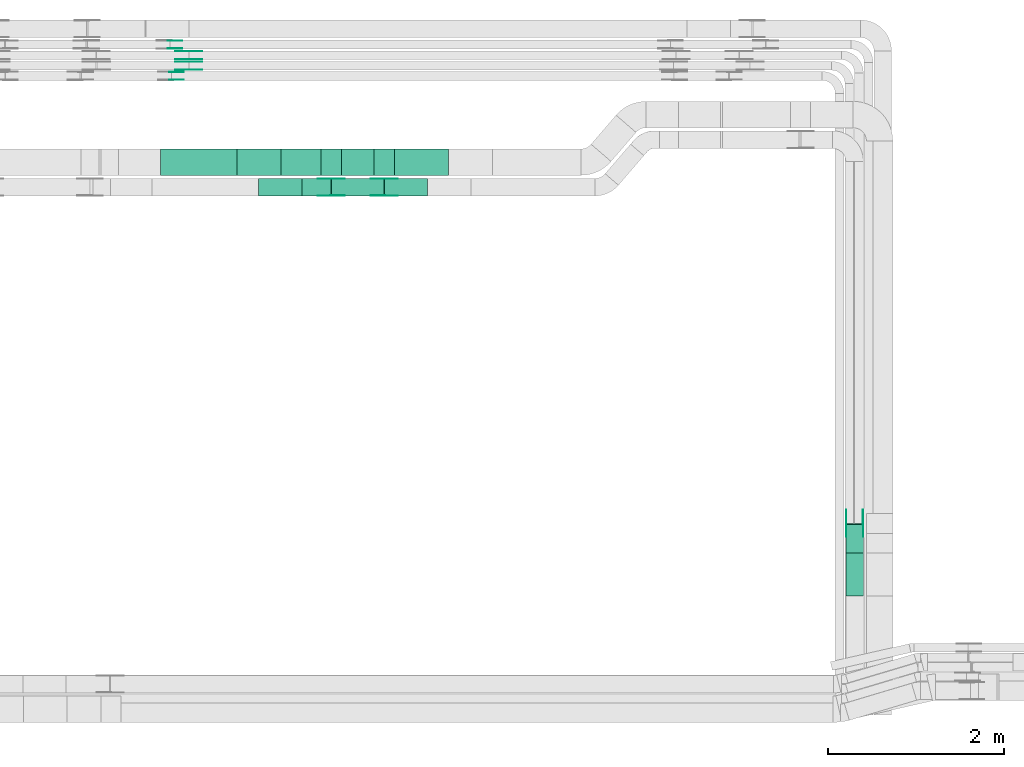
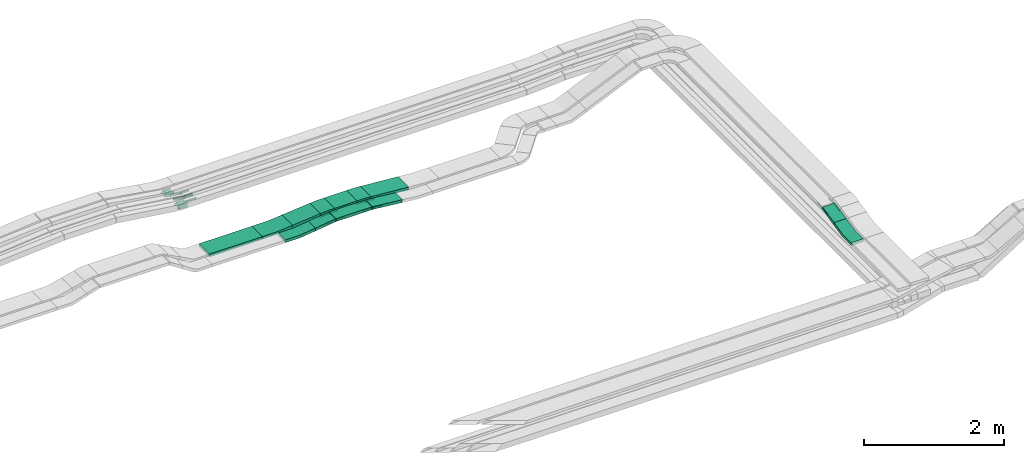
# One storey, part 21 of 31: 29 flow fittings, 8 flow segments.
"""IFC2X3 building model written with IfcOpenShell, lengths in millimetres."""

from ifc_helpers import new_model, entity, si_unit, converted_unit, derived_unit, direction, frame, frame_2d, origin, origin_2d_with_axis, place, context, subcontext, project, spatial, polyline, circle_curve, parameter, trimmed, segment, composite_curve, rectangle, outline, extrude, source, transform, mapped, material, type_object, type_shapes, element, save


model = new_model("IFC2X3")

# Units and contexts
model_context = context("Model", 3, precision=0.01, world=origin(), true_north=direction((6.12303176911189e-17, 1.0)))
body_context = subcontext(model_context, "Body", "Model", "MODEL_VIEW")
ifc_project = project(units=[si_unit("LENGTHUNIT", "METRE", prefix="MILLI"), si_unit("AREAUNIT", "SQUARE_METRE"), si_unit("VOLUMEUNIT", "CUBIC_METRE"), converted_unit("PLANEANGLEUNIT", "DEGREE", entity("IfcRatioMeasure", 0.0174532925199433), si_unit("PLANEANGLEUNIT", "RADIAN"), dimensions=[0, 0, 0, 0, 0, 0, 0]), si_unit("MASSUNIT", "GRAM", prefix="KILO"), derived_unit("MASSDENSITYUNIT", [(si_unit("MASSUNIT", "GRAM", prefix="KILO"), 1), (si_unit("LENGTHUNIT", "METRE"), -3)]), derived_unit("MOMENTOFINERTIAUNIT", [(si_unit("LENGTHUNIT", "METRE"), 4)]), si_unit("TIMEUNIT", "SECOND"), si_unit("FREQUENCYUNIT", "HERTZ"), si_unit("THERMODYNAMICTEMPERATUREUNIT", "DEGREE_CELSIUS"), derived_unit("THERMALTRANSMITTANCEUNIT", [(si_unit("MASSUNIT", "GRAM", prefix="KILO"), 1), (si_unit("THERMODYNAMICTEMPERATUREUNIT", "KELVIN"), -1), (si_unit("TIMEUNIT", "SECOND"), -3)]), derived_unit("VOLUMETRICFLOWRATEUNIT", [(si_unit("LENGTHUNIT", "METRE"), 3), (si_unit("TIMEUNIT", "SECOND"), -1)]), derived_unit("MASSFLOWRATEUNIT", [(si_unit("MASSUNIT", "GRAM", prefix="KILO"), 1), (si_unit("TIMEUNIT", "SECOND"), -1)]), derived_unit("ROTATIONALFREQUENCYUNIT", [(si_unit("TIMEUNIT", "SECOND"), -1)]), si_unit("ELECTRICCURRENTUNIT", "AMPERE"), si_unit("ELECTRICVOLTAGEUNIT", "VOLT"), si_unit("POWERUNIT", "WATT"), si_unit("FORCEUNIT", "NEWTON", prefix="KILO"), si_unit("ILLUMINANCEUNIT", "LUX"), si_unit("LUMINOUSFLUXUNIT", "LUMEN"), si_unit("LUMINOUSINTENSITYUNIT", "CANDELA"), derived_unit("USERDEFINED", [(si_unit("MASSUNIT", "GRAM", prefix="KILO"), -1), (si_unit("LENGTHUNIT", "METRE"), -2), (si_unit("TIMEUNIT", "SECOND"), 3), (si_unit("LUMINOUSFLUXUNIT", "LUMEN"), 1)]), derived_unit("LINEARVELOCITYUNIT", [(si_unit("LENGTHUNIT", "METRE"), 1), (si_unit("TIMEUNIT", "SECOND"), -1)]), si_unit("PRESSUREUNIT", "PASCAL"), derived_unit("USERDEFINED", [(si_unit("LENGTHUNIT", "METRE"), -2), (si_unit("MASSUNIT", "GRAM", prefix="KILO"), 1), (si_unit("TIMEUNIT", "SECOND"), -2)]), derived_unit("LINEARFORCEUNIT", [(si_unit("MASSUNIT", "GRAM", prefix="KILO"), 1), (si_unit("LENGTHUNIT", "METRE"), 1), (si_unit("TIMEUNIT", "SECOND"), -2), (si_unit("LENGTHUNIT", "METRE"), -1)]), derived_unit("PLANARFORCEUNIT", [(si_unit("MASSUNIT", "GRAM", prefix="KILO"), 1), (si_unit("LENGTHUNIT", "METRE"), 1), (si_unit("TIMEUNIT", "SECOND"), -2), (si_unit("LENGTHUNIT", "METRE"), -2)])], contexts=[model_context])

# Site, building, storey
site_placement = place(None, frame((0.0, -0.00077364408347762, 0.0)))
site = spatial("IfcSite", under=ifc_project, at=site_placement, CompositionType="ELEMENT")
building_placement = place(site_placement, origin())
building = spatial("IfcBuilding", under=site, at=building_placement, CompositionType="ELEMENT")
storey_placement = place(building_placement, frame((0.0, 0.0, 15900.0)))
storey = spatial("IfcBuildingStorey", under=building, at=storey_placement, CompositionType="ELEMENT", Elevation=15900.0)

# Flow segments
cable_carrier_segment_type = type_object("IfcCableCarrierSegmentType", PredefinedType="CABLETRAYSEGMENT")
flow_segment_1_placement = place(storey_placement, frame((52457.5745025818, 14435.0255085139, 2510.0)))
element("IfcFlowSegment", 1, at=flow_segment_1_placement, inside=storey, type_object=cable_carrier_segment_type, context=body_context, shape_type="SweptSolid", body=[
    extrude(rectangle(XDim=871.430907386971, YDim=300.000000000001, at=frame_2d((0.0, -1.08002495835535e-12), x_axis=(1.0, 0.0))), frame((435.715453693494, 150.0, 0.0)), (0.0, 0.0, 1.0), 50.0000000000038),
])
flow_segment_2_placement = place(storey_placement, frame((54513.7420303516, 14435.0255085139, 2586.29740849039)))
element("IfcFlowSegment", 2, at=flow_segment_2_placement, inside=storey, type_object=cable_carrier_segment_type, context=body_context, shape_type="SweptSolid", body=[
    extrude(rectangle(XDim=370.439682383992, YDim=300.000000000001, at=frame_2d((0.0, -1.08002495835535e-12), x_axis=(1.0, 0.0))), frame((185.219841191996, 150.0, 0.0), z_axis=(0.0, 0.0, 1.0), x_axis=(-1.0, 0.0, 0.0)), (0.0, 0.0, 1.0), 50.0000000000016),
])
flow_segment_3_placement = place(storey_placement, frame((54402.548878296, 14200.0255085138, 2586.29740849033)))
element("IfcFlowSegment", 3, at=flow_segment_3_placement, inside=storey, type_object=cable_carrier_segment_type, context=body_context, shape_type="SweptSolid", body=[
    extrude(rectangle(XDim=593.343795790922, YDim=199.999999999998, at=frame_2d((0.0, -1.08002495835535e-12), x_axis=(1.0, 0.0))), frame((296.671897895461, 100.0, 0.0)), (0.0, 0.0, 1.0), 50.0000000000016),
])
flow_segment_4_placement = place(storey_placement, frame((54062.4426607783, 14200.0255085138, 2542.67482177643)))
element("IfcFlowSegment", 4, at=flow_segment_4_placement, inside=storey, type_object=cable_carrier_segment_type, context=body_context, shape_type="SweptSolid", body=[
    extrude(rectangle(XDim=49.9999999999994, YDim=199.999999999998, at=frame_2d((-5.6488147492928e-13, 0.0), x_axis=(1.0, 0.0))), frame((3.25358748530932, 100.0, 24.7873792175654), z_axis=(0.99149516870263, 0.0, 0.130143499412548), x_axis=(-0.130143499412548, 0.0, 0.99149516870263)), (0.0, 0.0, 1.0), 333.926965891303),
])
flow_segment_5_placement = place(storey_placement, frame((54998.2976444425, 14200.0255085138, 2535.70800950201)))
element("IfcFlowSegment", 5, at=flow_segment_5_placement, inside=storey, type_object=cable_carrier_segment_type, context=body_context, shape_type="SweptSolid", body=[
    extrude(rectangle(XDim=49.9999999999982, YDim=200.000000000002, at=frame_2d((0.0, -2.1564972030319e-12), x_axis=(0.0, 1.0))), frame((2.56402268188747, 100.0, 75.3339131478848), z_axis=(0.994726726442406, 0.0, -0.102560907275502), x_axis=(0.0, 1.0, 0.0)), (0.0, 0.0, 1.0), 492.05634317635),
])
flow_segment_6_placement = place(storey_placement, frame((53824.3802396061, 14435.0255085139, 2533.1755358989)))
element("IfcFlowSegment", 6, at=flow_segment_6_placement, inside=storey, type_object=cable_carrier_segment_type, context=body_context, shape_type="SweptSolid", body=[
    extrude(rectangle(XDim=50.0000000000003, YDim=300.000000000001, at=frame_2d((0.0, 0.0), x_axis=(0.0, 1.0))), frame((2.31258518134798, 150.0, 24.8928091982228), z_axis=(0.995712367928819, 0.0, 0.0925034072539187), x_axis=(0.0, 1.0, 0.0)), (0.0, 0.0, 1.0), 461.339846266049),
])
flow_segment_7_placement = place(storey_placement, frame((55110.300731982, 14435.0255085139, 2529.43421983494)))
element("IfcFlowSegment", 7, at=flow_segment_7_placement, inside=storey, type_object=cable_carrier_segment_type, context=body_context, shape_type="SweptSolid", body=[
    extrude(rectangle(XDim=49.9999999999992, YDim=300.000000000001, at=origin_2d_with_axis()), frame((1.94049037679315, 150.0, 72.9988713645046), z_axis=(0.996983046674374, 0.0, -0.0776196150717272), x_axis=(0.0776196150717272, 0.0, 0.996983046674374)), (0.0, 0.0, 1.0), 619.357557407488),
])
flow_segment_8_placement = place(storey_placement, frame((60246.8175590596, 10142.2365684485, 2935.93007796763)))
element("IfcFlowSegment", 8, at=flow_segment_8_placement, inside=storey, type_object=cable_carrier_segment_type, context=body_context, shape_type="SweptSolid", body=[
    extrude(rectangle(XDim=49.999999999999, YDim=333.777983077564, at=frame_2d((1.05160324892495e-12, -2.39808173319034e-13), x_axis=(0.0, 1.0))), frame((0.0, 168.288031645758, 61.2571478959587), z_axis=(1.0, 0.0, 0.0), x_axis=(0.0, -0.975283876332617, -0.220955562422909)), (0.0, 0.0, 1.0), 200.000000000007),
])

# Flow fittings
ifc_material_1 = material(Name="G")
cable_carrier_fitting_type_1 = type_object("IfcCableCarrierFittingType", PredefinedType="NOTDEFINED", material=ifc_material_1)
shared_shape_1 = source(origin(), body_context, "Body", "SweptSolid", [
    extrude(outline(composite_curve([segment(trimmed(circle_curve(frame_2d((-44.5901162790698, 0.0), x_axis=(1.0, 0.0)), 12.5), [parameter(90.0000000000007)], [parameter(270.0)], True, "PARAMETER"), True, "CONTINUOUS"), segment(polyline([(-44.5901162790697, -12.5), (-33.0901162790698, -12.5)]), True, "CONTINUOUS"), segment(polyline([(-33.0901162790698, -12.5), (-31.2296511627907, -14.5)]), True, "CONTINUOUS"), segment(polyline([(-31.2296511627907, -14.5), (108.90988372093, -14.5)]), True, "CONTINUOUS"), segment(polyline([(108.90988372093, -14.5), (108.90988372093, 14.5)]), True, "CONTINUOUS"), segment(polyline([(108.90988372093, 14.5), (-31.2296511627907, 14.5)]), True, "CONTINUOUS"), segment(polyline([(-31.2296511627907, 14.5), (-33.0901162790698, 12.5)]), True, "CONTINUOUS"), segment(polyline([(-33.0901162790698, 12.5), (-44.5901162790699, 12.5)]), True, "CONTINUOUS")], self_intersect=False)), frame((44.5901162790698, 0.0, 0.0), z_axis=(0.0, 0.0, -1.0), x_axis=(1.0, 0.0, 0.0)), (0.0, 0.0, -1.0), 2.0),
])
type_shapes(cable_carrier_fitting_type_1, [shared_shape_1])
for number, where, z_axis, x_axis in (
    (9, (52777.8189794615, 15633.9980000417, 2642.36325714286), (0.0, -1.0, 0.0), (1.0, 0.0, 0.0)),
    (10, (52777.8212949036, 15753.9980000417, 2642.36207118772), (0.0, -1.0, 0.0), (1.0, 0.0, 0.0)),
    (11, (60442.2775590698, 10477.4277933439, 3035.0), (1.0, 0.0, 0.0), (0.0, -0.975283876332616, -0.220955562422916)),
    (12, (54399.653738633, 14204.5655085037, 2611.29740849034), (0.0, -1.0, 0.0), (-0.991495168702633, 0.0, -0.130143499412525)),
    (13, (54998.383738638, 14395.485508524, 2611.29740849035), (0.0, 1.0, 0.0), (0.994726726442407, 0.0, -0.1025609072755)),
):
    element("IfcFlowFitting", number, at=place(storey_placement, frame(where, z_axis=z_axis, x_axis=x_axis)), inside=storey, type_object=cable_carrier_fitting_type_1, material=ifc_material_1, context=body_context, shape_type="MappedRepresentation", body=[
        mapped(shared_shape_1, transform((0.0, 0.0, 0.0), scale=1.0)),
    ])
cable_carrier_fitting_type_2 = type_object("IfcCableCarrierFittingType", PredefinedType="NOTDEFINED", material=ifc_material_1)
shared_shape_2 = source(origin(), body_context, "Body", "SweptSolid", [
    extrude(outline(composite_curve([segment(trimmed(circle_curve(frame_2d((-44.5901162790697, 0.0), x_axis=(1.0, 0.0)), 12.5), [parameter(90.0000000000007)], [parameter(270.0)], True, "PARAMETER"), True, "CONTINUOUS"), segment(polyline([(-44.5901162790697, -12.5), (-33.0901162790697, -12.5)]), True, "CONTINUOUS"), segment(polyline([(-33.0901162790697, -12.5), (-31.2296511627907, -14.5)]), True, "CONTINUOUS"), segment(polyline([(-31.2296511627907, -14.5), (108.90988372093, -14.5)]), True, "CONTINUOUS"), segment(polyline([(108.90988372093, -14.5), (108.90988372093, 14.5)]), True, "CONTINUOUS"), segment(polyline([(108.90988372093, 14.5), (-31.2296511627907, 14.5)]), True, "CONTINUOUS"), segment(polyline([(-31.2296511627907, 14.5), (-33.0901162790698, 12.5)]), True, "CONTINUOUS"), segment(polyline([(-33.0901162790698, 12.5), (-44.5901162790699, 12.5)]), True, "CONTINUOUS")], self_intersect=False)), frame((44.5901162790697, 0.0, 0.0)), (0.0, 0.0, 1.0), 2.0),
])
type_shapes(cable_carrier_fitting_type_2, [shared_shape_2])
for number, where, z_axis, x_axis in (
    (14, (52777.8189794615, 15724.918000062, 2642.36325714286), (0.0, 1.0, 0.0), (1.0, 0.0, 0.0)),
    (15, (52777.8212949035, 15844.918000062, 2642.36207118771), (0.0, 1.0, 0.0), (1.0, 0.0, 0.0)),
    (16, (60251.3575590495, 10477.4277933439, 3035.0), (-1.0, 0.0, 0.0), (0.0, -0.975283876332616, -0.220955562422916)),
    (17, (54399.653738633, 14395.485508524, 2611.29740849035), (0.0, 1.0, 0.0), (-0.991495168702633, 0.0, -0.130143499412525)),
    (18, (54998.383738638, 14204.5655085037, 2611.29740849036), (0.0, -1.0, 0.0), (0.994726726442407, 0.0, -0.1025609072755)),
):
    element("IfcFlowFitting", number, at=place(storey_placement, frame(where, z_axis=z_axis, x_axis=x_axis)), inside=storey, type_object=cable_carrier_fitting_type_2, material=ifc_material_1, context=body_context, shape_type="MappedRepresentation", body=[
        mapped(shared_shape_2, transform((0.0, 0.0, 0.0), scale=1.0)),
    ])
cable_carrier_fitting_type_3 = type_object("IfcCableCarrierFittingType", PredefinedType="NOTDEFINED", material=ifc_material_1)
shared_shape_3 = source(origin(), body_context, "Body", "SweptSolid", [
    extrude(outline(composite_curve([segment(trimmed(circle_curve(frame_2d((-44.5901162790698, 0.0), x_axis=(1.0, 0.0)), 12.5), [parameter(90.0000000000007)], [parameter(270.0)], True, "PARAMETER"), True, "CONTINUOUS"), segment(polyline([(-44.5901162790697, -12.5), (-33.0901162790698, -12.5)]), True, "CONTINUOUS"), segment(polyline([(-33.0901162790698, -12.5), (-31.2296511627907, -14.5)]), True, "CONTINUOUS"), segment(polyline([(-31.2296511627907, -14.5), (108.90988372093, -14.5)]), True, "CONTINUOUS"), segment(polyline([(108.90988372093, -14.5), (108.90988372093, 14.5)]), True, "CONTINUOUS"), segment(polyline([(108.90988372093, 14.5), (-31.2296511627907, 14.5)]), True, "CONTINUOUS"), segment(polyline([(-31.2296511627907, 14.5), (-33.0901162790698, 12.5)]), True, "CONTINUOUS"), segment(polyline([(-33.0901162790698, 12.5), (-44.5901162790699, 12.5)]), True, "CONTINUOUS")], self_intersect=False)), frame((44.5901162790698, 0.0, 0.0), z_axis=(0.0, 0.0, -1.0), x_axis=(1.0, 0.0, 0.0)), (0.0, 0.0, -1.0), 2.0),
])
type_shapes(cable_carrier_fitting_type_3, [shared_shape_3])
for number, where, z_axis, x_axis in (
    (19, (52777.8189794615, 15722.918000062, 2642.36325714286), (0.0, 1.0, 0.0), (-0.990595007167102, 0.0, 0.136826648631067)),
    (20, (52777.8212949036, 15842.918000062, 2642.36207118772), (0.0, 1.0, 0.0), (-0.990663695538518, 0.0, 0.136328435559007)),
    (21, (60253.3575590495, 10477.4277933439, 3035.0), (-1.0, 0.0, 0.0), (0.0, 1.0, 0.0)),
    (22, (54399.653738633, 14393.485508524, 2611.29740849034), (0.0, 1.0, 0.0), (1.0, 0.0, 0.0)),
    (23, (54998.3837386381, 14206.5655085037, 2611.29740849035), (0.0, -1.0, 0.0), (-1.0, 0.0, 0.0)),
):
    element("IfcFlowFitting", number, at=place(storey_placement, frame(where, z_axis=z_axis, x_axis=x_axis)), inside=storey, type_object=cable_carrier_fitting_type_3, material=ifc_material_1, context=body_context, shape_type="MappedRepresentation", body=[
        mapped(shared_shape_3, transform((0.0, 0.0, 0.0), scale=1.0)),
    ])
cable_carrier_fitting_type_4 = type_object("IfcCableCarrierFittingType", PredefinedType="NOTDEFINED", material=ifc_material_1)
shared_shape_4 = source(origin(), body_context, "Body", "SweptSolid", [
    extrude(outline(composite_curve([segment(trimmed(circle_curve(frame_2d((-44.5901162790697, 0.0), x_axis=(1.0, 0.0)), 12.5), [parameter(90.0000000000007)], [parameter(270.0)], True, "PARAMETER"), True, "CONTINUOUS"), segment(polyline([(-44.5901162790697, -12.5), (-33.0901162790697, -12.5)]), True, "CONTINUOUS"), segment(polyline([(-33.0901162790697, -12.5), (-31.2296511627907, -14.5)]), True, "CONTINUOUS"), segment(polyline([(-31.2296511627907, -14.5), (108.90988372093, -14.5)]), True, "CONTINUOUS"), segment(polyline([(108.90988372093, -14.5), (108.90988372093, 14.5)]), True, "CONTINUOUS"), segment(polyline([(108.90988372093, 14.5), (-31.2296511627907, 14.5)]), True, "CONTINUOUS"), segment(polyline([(-31.2296511627907, 14.5), (-33.0901162790698, 12.5)]), True, "CONTINUOUS"), segment(polyline([(-33.0901162790698, 12.5), (-44.5901162790699, 12.5)]), True, "CONTINUOUS")], self_intersect=False)), frame((44.5901162790697, 0.0, 0.0)), (0.0, 0.0, 1.0), 2.0),
])
type_shapes(cable_carrier_fitting_type_4, [shared_shape_4])
for number, where, z_axis, x_axis in (
    (24, (52777.8189794615, 15635.9980000417, 2642.36325714287), (0.0, -1.0, 0.0), (-0.990595007167102, 0.0, 0.136826648631067)),
    (25, (52777.8212949036, 15755.9980000417, 2642.36207118772), (0.0, -1.0, 0.0), (-0.990663695538518, 0.0, 0.136328435559007)),
    (26, (60440.2775590698, 10477.4277933439, 3035.0), (1.0, 0.0, 0.0), (0.0, 1.0, 0.0)),
    (27, (54399.653738633, 14206.5655085037, 2611.29740849034), (0.0, -1.0, 0.0), (1.0, 0.0, 0.0)),
    (28, (54998.3837386381, 14393.485508524, 2611.29740849035), (0.0, 1.0, 0.0), (-1.0, 0.0, 0.0)),
):
    element("IfcFlowFitting", number, at=place(storey_placement, frame(where, z_axis=z_axis, x_axis=x_axis)), inside=storey, type_object=cable_carrier_fitting_type_4, material=ifc_material_1, context=body_context, shape_type="MappedRepresentation", body=[
        mapped(shared_shape_4, transform((0.0, 0.0, 0.0), scale=1.0)),
    ])
cable_carrier_fitting_type_5 = type_object("IfcCableCarrierFittingType", PredefinedType="NOTDEFINED", material=ifc_material_1)
shared_shape_5 = source(origin(), body_context, "Body", "SweptSolid", [
    extrude(outline(composite_curve([segment(trimmed(circle_curve(frame_2d((-41.4651162790697, 0.0), x_axis=(1.0, 0.0)), 25.0), [parameter(90.0000000000007)], [parameter(270.0)], True, "PARAMETER"), True, "CONTINUOUS"), segment(polyline([(-41.4651162790697, -25.0), (-29.9651162790697, -25.0)]), True, "CONTINUOUS"), segment(polyline([(-29.9651162790697, -25.0), (-28.1046511627907, -38.5)]), True, "CONTINUOUS"), segment(polyline([(-28.1046511627907, -38.5), (99.5348837209303, -38.5)]), True, "CONTINUOUS"), segment(polyline([(99.5348837209303, -38.5), (99.5348837209303, 38.5)]), True, "CONTINUOUS"), segment(polyline([(99.5348837209303, 38.5), (-28.1046511627907, 38.5)]), True, "CONTINUOUS"), segment(polyline([(-28.1046511627907, 38.5), (-29.9651162790697, 25.0)]), True, "CONTINUOUS"), segment(polyline([(-29.9651162790697, 25.0), (-41.46511627907, 25.0)]), True, "CONTINUOUS")], self_intersect=False)), frame((41.4651162790697, 0.0, 0.0), z_axis=(0.0, 0.0, -1.0), x_axis=(1.0, 0.0, 0.0)), (0.0, 0.0, -1.0), 2.0),
])
type_shapes(cable_carrier_fitting_type_5, [shared_shape_5])
for number, where, z_axis, x_axis in (
    (29, (52562.0471184484, 15876.5339089845, 2665.0), (0.0, -1.0, 0.0), (1.0, 0.0, 0.0)),
    (30, (52578.4870270341, 15521.5339089845, 2667.02711976826), (0.0, -1.0, 0.0), (1.0, 0.0, 0.0)),
):
    element("IfcFlowFitting", number, at=place(storey_placement, frame(where, z_axis=z_axis, x_axis=x_axis)), inside=storey, type_object=cable_carrier_fitting_type_5, material=ifc_material_1, context=body_context, shape_type="MappedRepresentation", body=[
        mapped(shared_shape_5, transform((0.0, 0.0, 0.0), scale=1.0)),
    ])
cable_carrier_fitting_type_6 = type_object("IfcCableCarrierFittingType", PredefinedType="NOTDEFINED", material=ifc_material_1)
shared_shape_6 = source(origin(), body_context, "Body", "SweptSolid", [
    extrude(outline(composite_curve([segment(trimmed(circle_curve(frame_2d((-41.4651162790697, 0.0), x_axis=(1.0, 0.0)), 25.0), [parameter(90.0000000000007)], [parameter(270.0)], True, "PARAMETER"), True, "CONTINUOUS"), segment(polyline([(-41.4651162790697, -25.0), (-29.9651162790697, -25.0)]), True, "CONTINUOUS"), segment(polyline([(-29.9651162790697, -25.0), (-28.1046511627907, -38.5)]), True, "CONTINUOUS"), segment(polyline([(-28.1046511627907, -38.5), (99.5348837209303, -38.5)]), True, "CONTINUOUS"), segment(polyline([(99.5348837209303, -38.5), (99.5348837209303, 38.5)]), True, "CONTINUOUS"), segment(polyline([(99.5348837209303, 38.5), (-28.1046511627907, 38.5)]), True, "CONTINUOUS"), segment(polyline([(-28.1046511627907, 38.5), (-29.9651162790697, 25.0)]), True, "CONTINUOUS"), segment(polyline([(-29.9651162790697, 25.0), (-41.46511627907, 25.0)]), True, "CONTINUOUS")], self_intersect=False)), frame((41.4651162790697, 0.0, 0.0)), (0.0, 0.0, 1.0), 2.0),
])
type_shapes(cable_carrier_fitting_type_6, [shared_shape_6])
for number, where, z_axis, x_axis in (
    (31, (52562.0471184484, 15963.4539090049, 2665.0), (0.0, 1.0, 0.0), (1.0, 0.0, 0.0)),
    (32, (52578.4870270341, 15608.4539090049, 2667.02711976826), (0.0, 1.0, 0.0), (1.0, 0.0, 0.0)),
):
    element("IfcFlowFitting", number, at=place(storey_placement, frame(where, z_axis=z_axis, x_axis=x_axis)), inside=storey, type_object=cable_carrier_fitting_type_6, material=ifc_material_1, context=body_context, shape_type="MappedRepresentation", body=[
        mapped(shared_shape_6, transform((0.0, 0.0, 0.0), scale=1.0)),
    ])
ifc_material_2 = material()
cable_carrier_fitting_type_7 = type_object("IfcCableCarrierFittingType", Name="470_DKC_S5_CS 90 internal vertical angle:-", PredefinedType="NOTDEFINED", material=ifc_material_2)
shared_shape_7 = source(origin(), body_context, "Body", "SweptSolid", [
    extrude(outline(composite_curve([segment(polyline([(-248.884102004042, -33.4132193439377), (-8.59914921217461, -33.4132193439377)]), True, "CONTINUOUS"), segment(trimmed(circle_curve(frame_2d((-8.59914921217495, 131.586780656061), x_axis=(0.0, -1.0)), 164.999999999999), [parameter(0.0)], [parameter(7.47788467414994)], True, "PARAMETER"), True, "CONTINUOUS"), segment(polyline([(12.8745281908803, -32.0099221798735), (251.115897995958, -0.738397567383603)]), True, "CONTINUOUS"), segment(polyline([(251.115897995958, -0.738397567383603), (244.608723025336, 48.8363608677488)]), True, "CONTINUOUS"), segment(polyline([(244.608723025336, 48.8363608677488), (6.36735322025738, 17.5648362552588)]), True, "CONTINUOUS"), segment(trimmed(circle_curve(frame_2d((-8.59914921217495, 131.586780656061), x_axis=(0.0, -1.0)), 114.999999999999), [parameter(0.0)], [parameter(7.47788467414994)], True, "PARAMETER"), False, "CONTINUOUS"), segment(polyline([(-8.59914921217461, 16.5867806560626), (-248.884102004042, 16.5867806560626)]), True, "CONTINUOUS"), segment(polyline([(-248.884102004042, 16.5867806560626), (-248.884102004042, -33.4132193439377)]), True, "CONTINUOUS")], self_intersect=False)), frame((-0.549800885251438, 8.41321934393033, -100.0)), (0.0, 0.0, 1.0), 200.0),
])
type_shapes(cable_carrier_fitting_type_7, [shared_shape_7])
flow_fitting_1_placement = place(storey_placement, frame((53818.3837386383, 14300.0255085138, 2535.0), z_axis=(0.0, -1.0, 0.0), x_axis=(1.0, 0.0, 0.0)))
element("IfcFlowFitting", 33, at=flow_fitting_1_placement, inside=storey, type_object=cable_carrier_fitting_type_7, material=ifc_material_2, Name="470_DKC_S5_CS 90 internal vertical angle:-", ObjectType="470_DKC_S5_CS 90 internal vertical angle:-", context=body_context, shape_type="MappedRepresentation", body=[
    mapped(shared_shape_7, transform((0.0, 0.0, 0.0), scale=1.0)),
])
cable_carrier_fitting_type_8 = type_object("IfcCableCarrierFittingType", Name="470_DKC_S5_CS 90 internal vertical angle:-", PredefinedType="NOTDEFINED", material=ifc_material_2)
shared_shape_8 = source(origin(), body_context, "Body", "SweptSolid", [
    extrude(outline(composite_curve([segment(polyline([(-249.104062267323, -30.9171533967784), (-6.21488364976717, -30.9171533967784)]), True, "CONTINUOUS"), segment(trimmed(circle_curve(frame_2d((-6.21488364976746, 134.08284660322), x_axis=(0.0, -1.0)), 164.999999999999), [parameter(0.0)], [parameter(5.30764273649969)], True, "PARAMETER"), True, "CONTINUOUS"), segment(polyline([(9.04817854710052, -30.2096941050362), (250.895937732677, -7.74161749784905)]), True, "CONTINUOUS"), segment(polyline([(250.895937732677, -7.74161749784906), (246.27076736999, 42.044000898593)]), True, "CONTINUOUS"), segment(polyline([(246.27076736999, 42.044000898593), (4.42300818441319, 19.5759242914059)]), True, "CONTINUOUS"), segment(trimmed(circle_curve(frame_2d((-6.21488364976746, 134.08284660322), x_axis=(0.0, -1.0)), 114.999999999999), [parameter(0.0)], [parameter(5.30764273649969)], True, "PARAMETER"), False, "CONTINUOUS"), segment(polyline([(-6.21488364976716, 19.0828466032218), (-249.104062267323, 19.0828466032219)]), True, "CONTINUOUS"), segment(polyline([(-249.104062267323, 19.0828466032219), (-249.104062267323, -30.9171533967784)]), True, "CONTINUOUS")], self_intersect=False)), frame((-0.274266401924002, 5.91715339677117, -150.0)), (0.0, 0.0, 1.0), 300.0),
])
type_shapes(cable_carrier_fitting_type_8, [shared_shape_8])
flow_fitting_2_placement = place(storey_placement, frame((53578.383738638, 14585.0255085139, 2535.0), z_axis=(0.0, -1.0, 0.0), x_axis=(1.0, 0.0, 0.0)))
element("IfcFlowFitting", 34, at=flow_fitting_2_placement, inside=storey, type_object=cable_carrier_fitting_type_8, material=ifc_material_2, Name="470_DKC_S5_CS 90 internal vertical angle:-", ObjectType="470_DKC_S5_CS 90 internal vertical angle:-", context=body_context, shape_type="MappedRepresentation", body=[
    mapped(shared_shape_8, transform((0.0, 0.0, 0.0), scale=1.0)),
])
cable_carrier_fitting_type_9 = type_object("IfcCableCarrierFittingType", Name="470_DKC_S5_CD 90 external vertical angle:-", PredefinedType="NOTDEFINED", material=ifc_material_2)
shared_shape_9 = source(origin(), body_context, "Body", "SweptSolid", [
    extrude(outline(composite_curve([segment(polyline([(-113.957801689851, -27.8152537508677), (-7.517436817911, -27.8152537508677)]), True, "CONTINUOUS"), segment(trimmed(circle_curve(frame_2d((-7.51743681791134, 162.184746249131), x_axis=(0.0, -1.0)), 189.999999999999), [parameter(0.0)], [parameter(5.30764273649969)], True, "PARAMETER"), True, "CONTINUOUS"), segment(polyline([(10.0582105603003, -27.0006036573464), (116.042198310149, -17.1545072373602)]), True, "CONTINUOUS"), segment(polyline([(116.042198310149, -17.1545072373602), (111.417027947462, 32.6311111590818)]), True, "CONTINUOUS"), segment(polyline([(111.417027947462, 32.6311111590818), (5.43304019761297, 22.7850147390957)]), True, "CONTINUOUS"), segment(trimmed(circle_curve(frame_2d((-7.51743681791134, 162.184746249131), x_axis=(0.0, -1.0)), 139.999999999999), [parameter(0.0)], [parameter(5.30764273649969)], True, "PARAMETER"), False, "CONTINUOUS"), segment(polyline([(-7.517436817911, 22.1847462491326), (-113.957801689851, 22.1847462491325)]), True, "CONTINUOUS"), segment(polyline([(-113.957801689851, 22.1847462491325), (-113.957801689851, -27.8152537508677)]), True, "CONTINUOUS")], self_intersect=False)), frame((-0.130490028726613, 2.8152537508605, -150.0)), (0.0, 0.0, 1.0), 300.0),
])
type_shapes(cable_carrier_fitting_type_9, [shared_shape_9])
flow_fitting_3_placement = place(storey_placement, frame((54399.6537386329, 14585.0255085139, 2611.29740849039), z_axis=(0.0, -1.0, 0.0), x_axis=(-1.0, 0.0, 0.0)))
element("IfcFlowFitting", 35, at=flow_fitting_3_placement, inside=storey, type_object=cable_carrier_fitting_type_9, material=ifc_material_2, Name="470_DKC_S5_CD 90 external vertical angle:-", ObjectType="470_DKC_S5_CD 90 external vertical angle:-", context=body_context, shape_type="MappedRepresentation", body=[
    mapped(shared_shape_9, transform((0.0, 0.0, 0.0), scale=1.0)),
])
cable_carrier_fitting_type_10 = type_object("IfcCableCarrierFittingType", Name="470_DKC_S5_CD 90 external vertical angle:-", PredefinedType="NOTDEFINED", material=ifc_material_2)
shared_shape_10 = source(origin(), body_context, "Body", "SweptSolid", [
    extrude(outline(composite_curve([segment(polyline([(-114.111053205997, -27.3405286474183), (-6.32231984901271, -27.3405286474183)]), True, "CONTINUOUS"), segment(trimmed(circle_curve(frame_2d((-6.32231984901306, 162.659471352581), x_axis=(0.0, -1.0)), 189.999999999999), [parameter(0.0)], [parameter(4.45175416362981)], True, "PARAMETER"), True, "CONTINUOUS"), segment(polyline([(8.42540701458427, -26.7673075155517), (115.888946794003, -18.4007875233313)]), True, "CONTINUOUS"), segment(polyline([(115.888946794003, -18.4007875233313), (112.007966040425, 31.4483648103883)]), True, "CONTINUOUS"), segment(polyline([(112.007966040425, 31.4483648103883), (4.54442626100598, 23.0818448181678)]), True, "CONTINUOUS"), segment(trimmed(circle_curve(frame_2d((-6.32231984901306, 162.659471352581), x_axis=(0.0, -1.0)), 139.999999999999), [parameter(0.0)], [parameter(4.45175416362981)], True, "PARAMETER"), False, "CONTINUOUS"), segment(polyline([(-6.32231984901271, 22.659471352582), (-114.111053205997, 22.659471352582)]), True, "CONTINUOUS"), segment(polyline([(-114.111053205997, 22.659471352582), (-114.111053205997, -27.3405286474183)]), True, "CONTINUOUS")], self_intersect=False)), frame((-0.0909726965188889, 2.34052864741107, -150.0)), (0.0, 0.0, 1.0), 300.0),
])
type_shapes(cable_carrier_fitting_type_10, [shared_shape_10])
flow_fitting_4_placement = place(storey_placement, frame((54998.3837386381, 14585.0255085139, 2611.29740849039), z_axis=(0.0, 1.0, 0.0), x_axis=(1.0, 0.0, 0.0)))
element("IfcFlowFitting", 36, at=flow_fitting_4_placement, inside=storey, type_object=cable_carrier_fitting_type_10, material=ifc_material_2, Name="470_DKC_S5_CD 90 external vertical angle:-", ObjectType="470_DKC_S5_CD 90 external vertical angle:-", context=body_context, shape_type="MappedRepresentation", body=[
    mapped(shared_shape_10, transform((0.0, 0.0, 0.0), scale=1.0)),
])
cable_carrier_fitting_type_11 = type_object("IfcCableCarrierFittingType", Name="470_DKC_S5_CS 90 internal vertical angle:-", PredefinedType="NOTDEFINED", material=ifc_material_2)
shared_shape_11 = source(origin(), body_context, "Body", "SweptSolid", [
    extrude(outline(composite_curve([segment(polyline([(-248.688096365734, -39.6931080473411), (-14.0168484735833, -39.6931080473411)]), True, "CONTINUOUS"), segment(trimmed(circle_curve(frame_2d((-14.0168484735836, 125.306891952658), x_axis=(0.0, -1.0)), 164.999999999999), [parameter(0.0)], [parameter(12.7651639618243)], True, "PARAMETER"), True, "CONTINUOUS"), segment(polyline([(22.4408193261969, -35.6149476422228), (251.311903634266, 16.2369699202739)]), True, "CONTINUOUS"), segment(polyline([(251.311903634266, 16.2369699202739), (240.26412551312, 65.001163736905)]), True, "CONTINUOUS"), segment(polyline([(240.26412551312, 65.001163736905), (11.3930412050512, 13.1492461744082)]), True, "CONTINUOUS"), segment(trimmed(circle_curve(frame_2d((-14.0168484735836, 125.306891952658), x_axis=(0.0, -1.0)), 114.999999999999), [parameter(0.0)], [parameter(12.7651639618243)], True, "PARAMETER"), False, "CONTINUOUS"), segment(polyline([(-14.0168484735833, 10.3068919526591), (-248.688096365734, 10.3068919526591)]), True, "CONTINUOUS"), segment(polyline([(-248.688096365734, 10.3068919526591), (-248.688096365734, -39.6931080473411)]), True, "CONTINUOUS")], self_intersect=False)), frame((-1.64357335733981, 14.6931080473338, -100.0)), (0.0, 0.0, 1.0), 200.0),
])
type_shapes(cable_carrier_fitting_type_11, [shared_shape_11])
flow_fitting_5_placement = place(storey_placement, frame((60346.8175590596, 9903.61601629266, 2905.0), z_axis=(1.0, 0.0, 0.0), x_axis=(0.0, 1.0, 0.0)))
element("IfcFlowFitting", 37, at=flow_fitting_5_placement, inside=storey, type_object=cable_carrier_fitting_type_11, material=ifc_material_2, Name="470_DKC_S5_CS 90 internal vertical angle:-", ObjectType="470_DKC_S5_CS 90 internal vertical angle:-", context=body_context, shape_type="MappedRepresentation", body=[
    mapped(shared_shape_11, transform((0.0, 0.0, 0.0), scale=1.0)),
])

save(model, "model.ifc")
